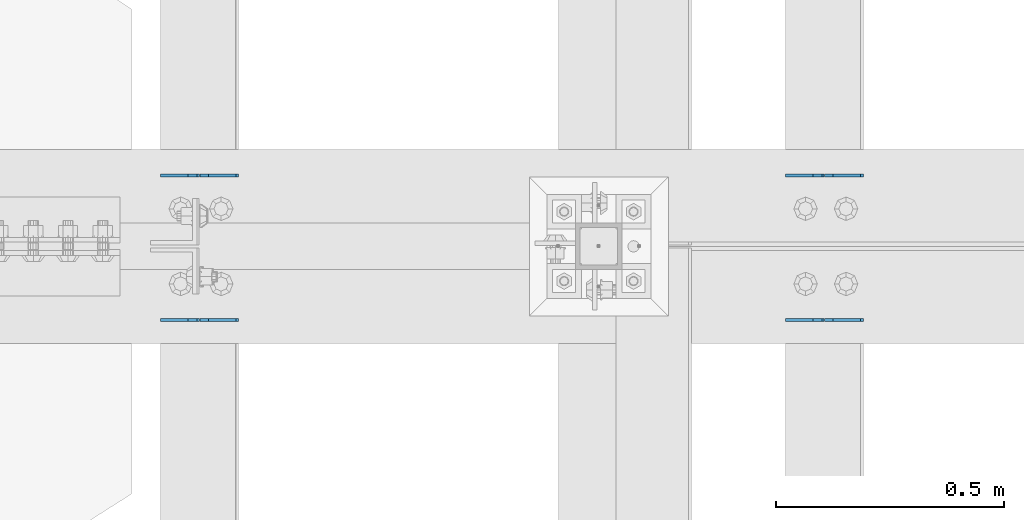
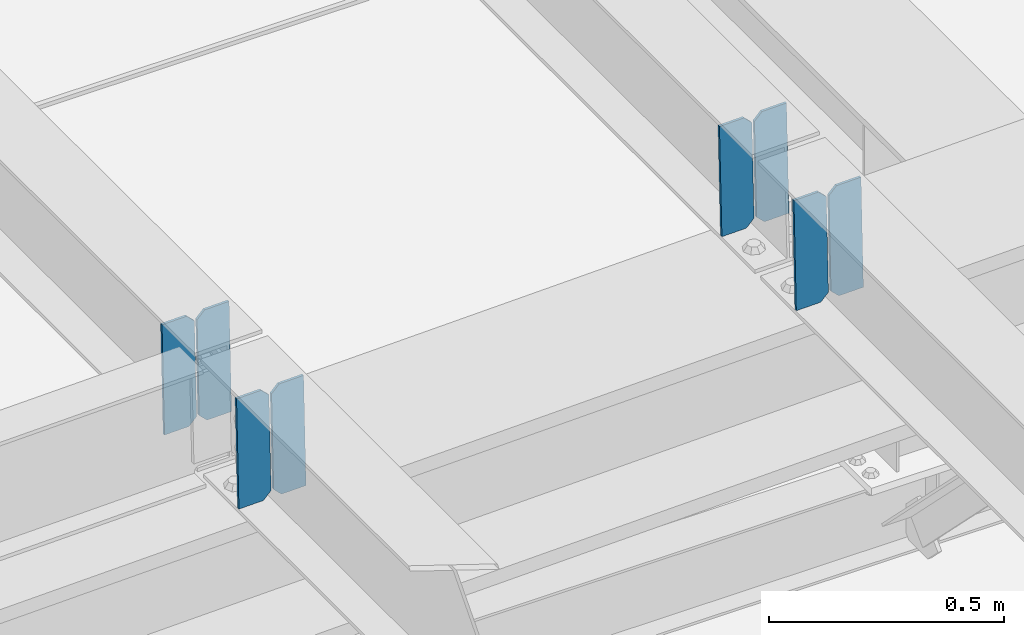
# One storey, part 3237 of 3843: 8 plates, 4 elements without a shape of their own.
"""IFC2X3 building model written with IfcOpenShell, lengths in millimetres."""

from ifc_helpers import new_model, si_unit, frame, origin_with_axes, place, context, subcontext, project, spatial, faceted_brep, material, type_object, element, aggregate, save


model = new_model("IFC2X3")

# Units and contexts
model_context = context("Model", 3, precision=1e-05, world=origin_with_axes())
body_context = subcontext(model_context, "Body", "Model", "MODEL_VIEW")
ifc_project = project(units=[si_unit("LENGTHUNIT", "METRE", prefix="MILLI"), si_unit("AREAUNIT", "SQUARE_METRE"), si_unit("VOLUMEUNIT", "CUBIC_METRE"), si_unit("MASSUNIT", "GRAM", prefix="KILO"), si_unit("TIMEUNIT", "SECOND"), si_unit("PLANEANGLEUNIT", "RADIAN"), si_unit("SOLIDANGLEUNIT", "STERADIAN"), si_unit("THERMODYNAMICTEMPERATUREUNIT", "DEGREE_CELSIUS"), si_unit("LUMINOUSINTENSITYUNIT", "LUMEN")], contexts=[model_context])

# Site, building, storey
site_placement = place(None, origin_with_axes())
site = spatial("IfcSite", under=ifc_project, at=site_placement, CompositionType="ELEMENT")
building_placement = place(site_placement, origin_with_axes())
building = spatial("IfcBuilding", under=site, at=building_placement, Name="Undefined", CompositionType="ELEMENT")
storey_placement = place(building_placement, origin_with_axes())
storey = spatial("IfcBuildingStorey", under=building, at=storey_placement, Name="Undefined", CompositionType="ELEMENT", Elevation=0.0)

# Assembly, plates
assembly_1_placement = place(storey_placement, origin_with_axes())
assembly_1 = element("IfcElementAssembly", 1, at=assembly_1_placement, inside=storey, Name="BEAM", AssemblyPlace="NOTDEFINED", PredefinedType="RIGID_FRAME")
ifc_material = material(Name="STEEL/A572-50")
plate_type = type_object("IfcPlateType", PredefinedType="NOTDEFINED")
plate_1_placement = place(assembly_1_placement, frame((39401.4964782845, 42357.7578757696, 45503.0067930682), z_axis=(-0.0211520978244517, -0.000277875999927347, 0.999776230734935), x_axis=(-0.999776269348334, 6.33400000515396e-06, -0.0211520970073544)))
plate_1 = element("IfcPlate", 2, at=plate_1_placement, type_object=plate_type, material=ifc_material, Name="PLATE", context=body_context, shape_type="Brep", body=[
    faceted_brep([(0.0, -3.17499999999927, 0.0), (6.83940015733242e-10, -3.17499999996653, 288.924999998613), (6.54836185276508e-10, 3.17500000001746, 288.924999998591), (0.0, 3.17499999999927, 0.0), (60.3250007643655, -3.17500000017753, 288.924999998606), (60.3250007643219, 3.17499999979918, 288.924999998584), (79.3750000013097, -3.17500000025029, 269.875000761494), (79.375000001266, 3.17499999972642, 269.875000761487), (79.375000000713, -3.17500000026484, 19.0499992370605), (79.3750000006985, 3.17499999971187, 19.0499992370533), (60.325000763667, -3.17500000020664, -1.45519152283669e-11), (60.3250007636234, 3.17499999977736, -3.63797880709171e-11)], [[[0, 1, 2, 3]], [[1, 4, 5, 2]], [[4, 6, 7, 5]], [[6, 8, 9, 7]], [[8, 10, 11, 9]], [[10, 0, 3, 11]], [[5, 7, 9, 11, 3, 2]], [[10, 8, 6, 4, 1, 0]]]),
])
plate_2_placement = place(assembly_1_placement, frame((39315.7906575949, 42357.758379744, 45501.1935295374), z_axis=(-0.0211520978244517, -0.000277875999927347, 0.999776230734935), x_axis=(-0.999776269348334, 6.33400000515396e-06, -0.0211520970073544)))
plate_2 = element("IfcPlate", 3, at=plate_2_placement, type_object=plate_type, material=ifc_material, Name="PLATE", context=body_context, shape_type="Brep", body=[
    faceted_brep([(4.36557456851006e-11, -3.17499999998836, 19.0499992370969), (6.11180439591408e-10, -3.17499999996653, 269.875000761516), (5.96628524363041e-10, 3.17500000001746, 269.875000761502), (1.45519152283669e-11, 3.17499999998836, 19.0499992370824), (19.0499992376572, -3.17500000003201, 288.924999998606), (19.0499992376281, 3.1749999999447, 288.924999998584), (79.3750000013242, -3.17500000025029, 288.924999998591), (79.3750000013097, 3.1749999997337, 288.92499999857), (79.3750000006548, -3.17500000026484, -2.18278728425503e-11), (79.3750000006403, 3.17499999969732, -2.91038304567337e-11), (19.0499992370023, -3.17500000005384, 0.0), (19.0499992369587, 3.17499999992287, -1.45519152283669e-11)], [[[0, 1, 2, 3]], [[1, 4, 5, 2]], [[4, 6, 7, 5]], [[6, 8, 9, 7]], [[8, 10, 11, 9]], [[10, 0, 3, 11]], [[5, 7, 9, 11, 3, 2]], [[10, 8, 6, 4, 1, 0]]]),
])
aggregate(assembly_1, [plate_1, plate_2])

assembly_2_placement = place(storey_placement, origin_with_axes())
assembly_2 = element("IfcElementAssembly", 4, at=assembly_2_placement, inside=storey, Name="BEAM", AssemblyPlace="NOTDEFINED", PredefinedType="RIGID_FRAME")
plate_3_placement = place(assembly_2_placement, frame((39401.4964782743, 42040.6168535187, 45502.7244772412), z_axis=(-0.0211520981862632, -0.00148010699961742, 0.99977517373937), x_axis=(-0.999776269354784, 3.22880000190736e-05, -0.0211520730075225)))
plate_3 = element("IfcPlate", 5, at=plate_3_placement, type_object=plate_type, material=ifc_material, Name="PLATE", context=body_context, shape_type="Brep", body=[
    faceted_brep([(0.0, -3.17499999999927, 0.0), (6.83940015733242e-10, -3.17499999996653, 288.924999998613), (6.54836185276508e-10, 3.17500000001746, 288.924999998591), (0.0, 3.17499999999927, 0.0), (60.3250007643655, -3.17500000017753, 288.924999998606), (60.3250007643219, 3.17499999979918, 288.924999998584), (79.3750000013097, -3.17500000025029, 269.875000761494), (79.375000001266, 3.17499999972642, 269.875000761487), (79.375000000713, -3.17500000026484, 19.0499992370605), (79.3750000006985, 3.17499999971187, 19.0499992370533), (60.325000763667, -3.17500000020664, -1.45519152283669e-11), (60.3250007636234, 3.17499999977736, -3.63797880709171e-11)], [[[0, 1, 2, 3]], [[1, 4, 5, 2]], [[4, 6, 7, 5]], [[6, 8, 9, 7]], [[8, 10, 11, 9]], [[10, 0, 3, 11]], [[5, 7, 9, 11, 3, 2]], [[10, 8, 6, 4, 1, 0]]]),
])
plate_4_placement = place(assembly_2_placement, frame((39315.790657585, 42040.619537943, 45500.9112156282), z_axis=(-0.0211520981862632, -0.00148010699961742, 0.99977517373937), x_axis=(-0.999776269354784, 3.22880000190736e-05, -0.0211520730075225)))
plate_4 = element("IfcPlate", 6, at=plate_4_placement, type_object=plate_type, material=ifc_material, Name="PLATE", context=body_context, shape_type="Brep", body=[
    faceted_brep([(4.36557456851006e-11, -3.17499999998836, 19.0499992370969), (6.11180439591408e-10, -3.17499999996653, 269.875000761516), (5.96628524363041e-10, 3.17500000001746, 269.875000761502), (1.45519152283669e-11, 3.17499999998836, 19.0499992370824), (19.0499992376572, -3.17500000003201, 288.924999998606), (19.0499992376281, 3.1749999999447, 288.924999998584), (79.3750000013242, -3.17500000025029, 288.924999998591), (79.3750000013097, 3.1749999997337, 288.92499999857), (79.3750000006548, -3.17500000026484, -2.18278728425503e-11), (79.3750000006403, 3.17499999969732, -2.91038304567337e-11), (19.0499992370023, -3.17500000005384, 0.0), (19.0499992369587, 3.17499999992287, -1.45519152283669e-11)], [[[0, 1, 2, 3]], [[1, 4, 5, 2]], [[4, 6, 7, 5]], [[6, 8, 9, 7]], [[8, 10, 11, 9]], [[10, 0, 3, 11]], [[5, 7, 9, 11, 3, 2]], [[10, 8, 6, 4, 1, 0]]]),
])
aggregate(assembly_2, [plate_3, plate_4])

assembly_3_placement = place(storey_placement, origin_with_axes())
assembly_3 = element("IfcElementAssembly", 7, at=assembly_3_placement, inside=storey, Name="BEAM", AssemblyPlace="NOTDEFINED", PredefinedType="RIGID_FRAME")
plate_5_placement = place(assembly_3_placement, frame((38029.8964782885, 42357.7170830474, 45467.278912477), z_axis=(-0.0211520982178627, -0.000141091000055894, 0.999776259387225), x_axis=(-0.999776269342228, 3.1669999978437e-06, -0.0211520980072307)))
plate_5 = element("IfcPlate", 8, at=plate_5_placement, type_object=plate_type, material=ifc_material, Name="PLATE", context=body_context, shape_type="Brep", body=[
    faceted_brep([(0.0, -3.17499999999927, 0.0), (6.83940015733242e-10, -3.17499999996653, 288.924999998613), (6.54836185276508e-10, 3.17500000001746, 288.924999998591), (0.0, 3.17499999999927, 0.0), (60.3250007643655, -3.17500000017753, 288.924999998606), (60.3250007643219, 3.17499999979918, 288.924999998584), (79.3750000013097, -3.17500000025029, 269.875000761494), (79.375000001266, 3.17499999972642, 269.875000761487), (79.375000000713, -3.17500000026484, 19.0499992370605), (79.3750000006985, 3.17499999971187, 19.0499992370533), (60.325000763667, -3.17500000020664, -1.45519152283669e-11), (60.3250007636234, 3.17499999977736, -3.63797880709171e-11)], [[[0, 1, 2, 3]], [[1, 4, 5, 2]], [[4, 6, 7, 5]], [[6, 8, 9, 7]], [[8, 10, 11, 9]], [[10, 0, 3, 11]], [[5, 7, 9, 11, 3, 2]], [[10, 8, 6, 4, 1, 0]]]),
])
plate_6_placement = place(assembly_3_placement, frame((37944.1906575988, 42357.7173389388, 45465.4656488933), z_axis=(-0.0211520982178627, -0.000141091000055894, 0.999776259387225), x_axis=(-0.999776269342228, 3.1669999978437e-06, -0.0211520980072307)))
plate_6 = element("IfcPlate", 9, at=plate_6_placement, type_object=plate_type, material=ifc_material, Name="PLATE", context=body_context, shape_type="Brep", body=[
    faceted_brep([(4.36557456851006e-11, -3.17499999998836, 19.0499992370969), (6.11180439591408e-10, -3.17499999996653, 269.875000761516), (5.96628524363041e-10, 3.17500000001746, 269.875000761502), (1.45519152283669e-11, 3.17499999998836, 19.0499992370824), (19.0499992376572, -3.17500000003201, 288.924999998606), (19.0499992376281, 3.1749999999447, 288.924999998584), (79.3750000013242, -3.17500000025029, 288.924999998591), (79.3750000013097, 3.1749999997337, 288.92499999857), (79.3750000006548, -3.17500000026484, -2.18278728425503e-11), (79.3750000006403, 3.17499999969732, -2.91038304567337e-11), (19.0499992370023, -3.17500000005384, 0.0), (19.0499992369587, 3.17499999992287, -1.45519152283669e-11)], [[[0, 1, 2, 3]], [[1, 4, 5, 2]], [[4, 6, 7, 5]], [[6, 8, 9, 7]], [[8, 10, 11, 9]], [[10, 0, 3, 11]], [[5, 7, 9, 11, 3, 2]], [[10, 8, 6, 4, 1, 0]]]),
])
aggregate(assembly_3, [plate_5, plate_6])

assembly_4_placement = place(storey_placement, origin_with_axes())
assembly_4 = element("IfcElementAssembly", 10, at=assembly_4_placement, inside=storey, Name="BEAM", AssemblyPlace="NOTDEFINED", PredefinedType="RIGID_FRAME")
plate_7_placement = place(assembly_4_placement, frame((38029.8964782866, 42040.4015405942, 45467.1341697766), z_axis=(-0.0211520981049397, -0.000759152000093307, 0.999775981124772), x_axis=(-0.999776269340625, 1.63419999910023e-05, -0.0211520920071787)))
plate_7 = element("IfcPlate", 11, at=plate_7_placement, type_object=plate_type, material=ifc_material, Name="PLATE", context=body_context, shape_type="Brep", body=[
    faceted_brep([(0.0, -3.17499999999927, 0.0), (6.83940015733242e-10, -3.17499999996653, 288.924999998613), (6.54836185276508e-10, 3.17500000001746, 288.924999998591), (0.0, 3.17499999999927, 0.0), (60.3250007643655, -3.17500000017753, 288.924999998606), (60.3250007643219, 3.17499999979918, 288.924999998584), (79.3750000013097, -3.17500000025029, 269.875000761494), (79.375000001266, 3.17499999972642, 269.875000761487), (79.375000000713, -3.17500000026484, 19.0499992370605), (79.3750000006985, 3.17499999971187, 19.0499992370533), (60.325000763667, -3.17500000020664, -1.45519152283669e-11), (60.3250007636234, 3.17499999977736, -3.63797880709171e-11)], [[[0, 1, 2, 3]], [[1, 4, 5, 2]], [[4, 6, 7, 5]], [[6, 8, 9, 7]], [[8, 10, 11, 9]], [[10, 0, 3, 11]], [[5, 7, 9, 11, 3, 2]], [[10, 8, 6, 4, 1, 0]]]),
])
plate_8_placement = place(assembly_4_placement, frame((37944.1906575973, 42040.4029174437, 45465.3209066981), z_axis=(-0.0211520981049397, -0.000759152000093307, 0.999775981124772), x_axis=(-0.999776269340625, 1.63419999910023e-05, -0.0211520920071787)))
plate_8 = element("IfcPlate", 12, at=plate_8_placement, type_object=plate_type, material=ifc_material, Name="PLATE", context=body_context, shape_type="Brep", body=[
    faceted_brep([(4.36557456851006e-11, -3.17499999998836, 19.0499992370969), (6.11180439591408e-10, -3.17499999996653, 269.875000761516), (5.96628524363041e-10, 3.17500000001746, 269.875000761502), (1.45519152283669e-11, 3.17499999998836, 19.0499992370824), (19.0499992376572, -3.17500000003201, 288.924999998606), (19.0499992376281, 3.1749999999447, 288.924999998584), (79.3750000013242, -3.17500000025029, 288.924999998591), (79.3750000013097, 3.1749999997337, 288.92499999857), (79.3750000006548, -3.17500000026484, -2.18278728425503e-11), (79.3750000006403, 3.17499999969732, -2.91038304567337e-11), (19.0499992370023, -3.17500000005384, 0.0), (19.0499992369587, 3.17499999992287, -1.45519152283669e-11)], [[[0, 1, 2, 3]], [[1, 4, 5, 2]], [[4, 6, 7, 5]], [[6, 8, 9, 7]], [[8, 10, 11, 9]], [[10, 0, 3, 11]], [[5, 7, 9, 11, 3, 2]], [[10, 8, 6, 4, 1, 0]]]),
])
aggregate(assembly_4, [plate_7, plate_8])

save(model, "model.ifc")
